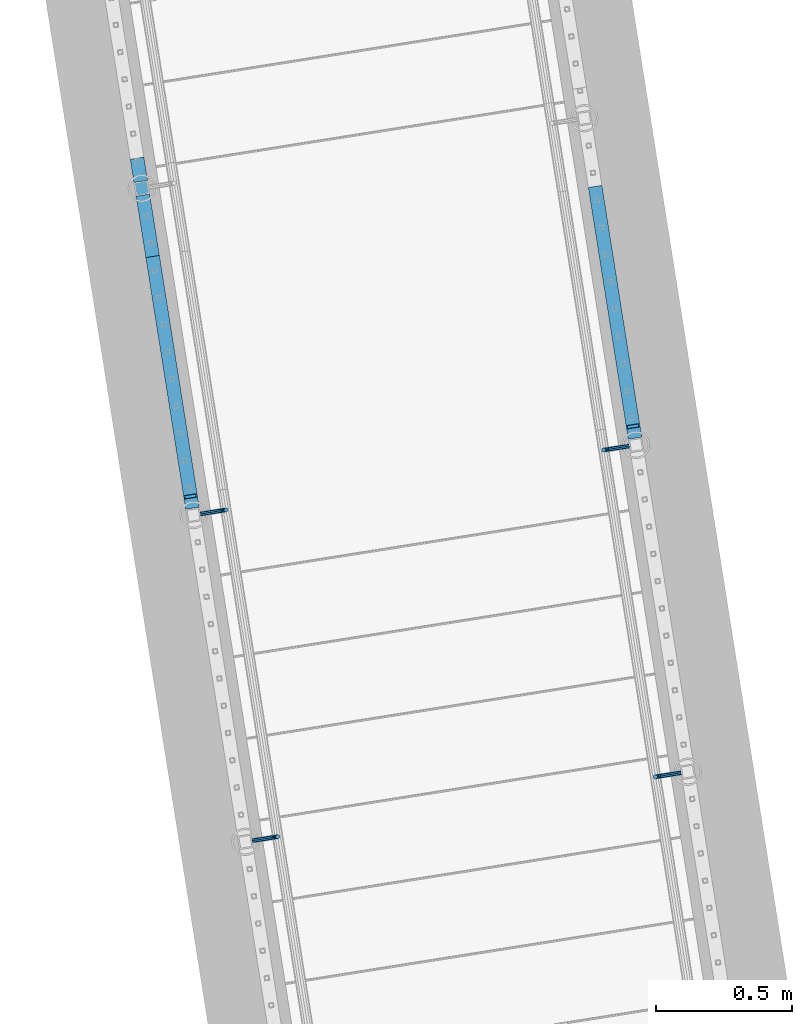
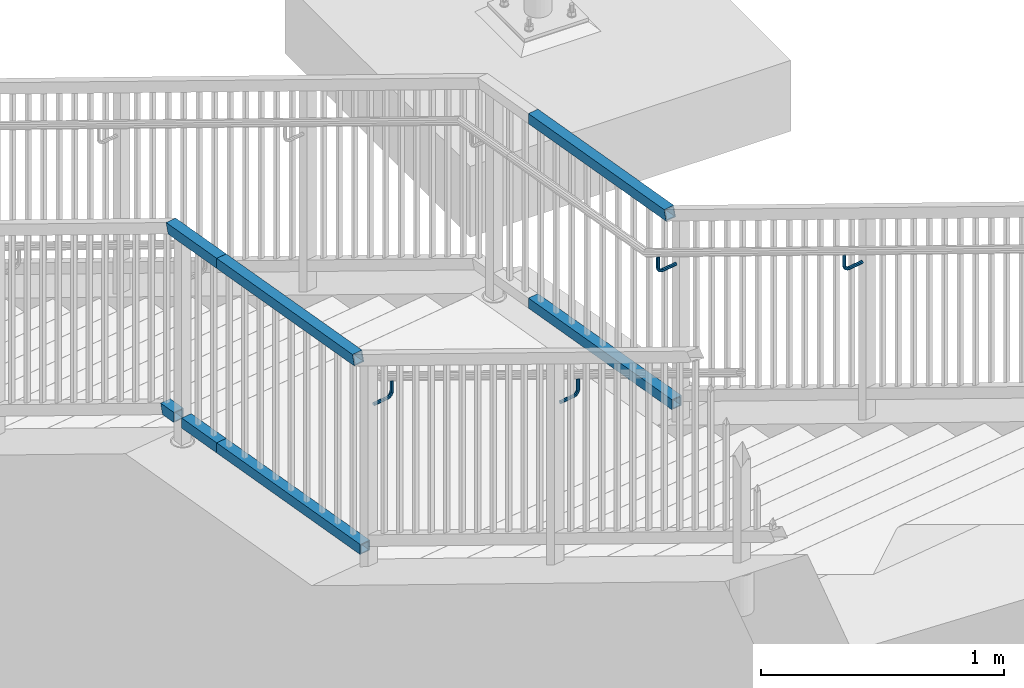
# One storey, part 436 of 975: 11 beams.
"""IFC2X3 building model written with IfcOpenShell, lengths in millimetres."""

import ifcopenshell
import ifcopenshell.guid

model = None  # the IFC model being written
_history = None  # IfcOwnerHistory: only IFC2X3 demands one
_inside = {}  # id of a spatial element -> (the spatial element, [elements in it])
_under = {}  # id of a project, library or spatial element -> (it, [spatial elements below it])
_declared = {}  # id of a project -> (the project, [libraries it declares])
_typed = {}  # id of a type object -> (the type object, [elements of that type])
_made_of = {}  # id of a material, layer set ... -> (it, [elements and type objects made of it])


def new_model(schema):
    """Start an empty IFC model of exactly this schema.

    Asked for "IFC4X3", IfcOpenShell would pick the latest addendum, in which some entities
    have other attributes; the version numbers below select the first issue.
    IFC2X3 requires an IfcOwnerHistory on every rooted entity: one is made here for all.
    """
    global model, _history
    if schema == "IFC4X3":
        model = ifcopenshell.file(schema_version=(4, 3, 0, 0))
    else:
        model = ifcopenshell.file(schema=schema)
    _inside.clear()
    _under.clear()
    _declared.clear()
    _typed.clear()
    _made_of.clear()
    _history = None
    if model.schema == "IFC2X3":
        org = make("IfcOrganization", Name="unknown")
        user = make(
            "IfcPersonAndOrganization",
            ThePerson=make("IfcPerson", FamilyName="unknown"),
            TheOrganization=org,
        )
        app = make(
            "IfcApplication",
            ApplicationDeveloper=org,
            Version="unknown",
            ApplicationFullName="unknown",
            ApplicationIdentifier="unknown",
        )
        _history = make(
            "IfcOwnerHistory",
            OwningUser=user,
            OwningApplication=app,
            ChangeAction="ADDED",
            CreationDate=0,
        )
    return model


def make(cls, **values):
    """One entity of the class cls with the attributes given. An attribute that is None is left unset."""
    return model.create_entity(
        cls, **{name: value for name, value in values.items() if value is not None}
    )


def rooted(cls, **values):
    """An entity with a GlobalId (a new one), such as an element, a storey or a relation."""
    return make(cls, GlobalId=ifcopenshell.guid.new(), OwnerHistory=_history, **values)


def si_unit(unit_type, name, prefix=None):
    """IfcSIUnit, for example si_unit("LENGTHUNIT", "METRE", prefix="MILLI")."""
    return make("IfcSIUnit", UnitType=unit_type, Prefix=prefix, Name=name)


def assignment(units):
    """IfcUnitAssignment: the units of a project."""
    return None if units is None else make("IfcUnitAssignment", Units=units)


def point(xyz):
    """IfcCartesianPoint."""
    return None if xyz is None else make("IfcCartesianPoint", Coordinates=xyz)


def direction(xyz):
    """IfcDirection."""
    return None if xyz is None else make("IfcDirection", DirectionRatios=xyz)


def frame(location, z_axis=None, x_axis=None):
    """IfcAxis2Placement3D, a coordinate frame: its origin and axes. An axis left out is left unset."""
    return make(
        "IfcAxis2Placement3D",
        Location=point(location),
        Axis=direction(z_axis),
        RefDirection=direction(x_axis),
    )


def origin_with_axes():
    """The frame at (0, 0, 0) with the z axis (0, 0, 1) and the x axis (1, 0, 0) written out."""
    return frame((0.0, 0.0, 0.0), z_axis=(0.0, 0.0, 1.0), x_axis=(1.0, 0.0, 0.0))


def place(relative_to, where):
    """IfcLocalPlacement: puts the frame where relative to a parent placement (None: the world)."""
    return make(
        "IfcLocalPlacement", PlacementRelTo=relative_to, RelativePlacement=where
    )


def context(
    kind, dimensions, precision=None, world=None, true_north=None, identifier=None
):
    """IfcGeometricRepresentationContext, for example the 3D "Model" context."""
    return make(
        "IfcGeometricRepresentationContext",
        ContextIdentifier=identifier,
        ContextType=kind,
        CoordinateSpaceDimension=dimensions,
        Precision=precision,
        WorldCoordinateSystem=world,
        TrueNorth=true_north,
    )


def subcontext(parent, identifier, kind, view, scale=None):
    """IfcGeometricRepresentationSubContext, for example "Body" below "Model"."""
    return make(
        "IfcGeometricRepresentationSubContext",
        ContextIdentifier=identifier,
        ContextType=kind,
        ParentContext=parent,
        TargetScale=scale,
        TargetView=view,
    )


def project(units=None, contexts=None):
    """IfcProject with its units and contexts."""
    return rooted(
        "IfcProject",
        Name="project",
        RepresentationContexts=contexts,
        UnitsInContext=assignment(units),
    )


def spatial(cls, under=None, at=None, **own):
    """A site, building, storey or space (cls), placed at a placement, below another one or the project."""
    s = rooted(cls, ObjectPlacement=at, **own)
    if under is not None:
        _under.setdefault(under.id(), (under, []))[1].append(s)
    return s


def faces_of(points, faces, orient=None, outer=None):
    """IfcFace entities. A face is a list of loops; a loop is a list of indices into points, from 0.

    orient and outer hold one flag for each loop. By default every Orientation is true, the
    first loop of a face is its IfcFaceOuterBound and the others are IfcFaceBound.
    """
    made = []
    for i, loops in enumerate(faces):
        bounds = []
        for j, loop in enumerate(loops):
            is_outer = j == 0 if outer is None else outer[i][j]
            bounds.append(
                make(
                    "IfcFaceOuterBound" if is_outer else "IfcFaceBound",
                    Bound=make("IfcPolyLoop", Polygon=[points[k] for k in loop]),
                    Orientation=True if orient is None else orient[i][j],
                )
            )
        made.append(make("IfcFace", Bounds=bounds))
    return made


def faceted_brep(points, faces, orient=None, outer=None, voids=None):
    """IfcFacetedBrep: a solid bounded by flat faces; with voids (closed shells), ...WithVoids."""
    shared = [point(p) for p in points]
    hull = make("IfcClosedShell", CfsFaces=faces_of(shared, faces, orient, outer))
    if voids is None:
        return make("IfcFacetedBrep", Outer=hull)
    return make(
        "IfcFacetedBrepWithVoids",
        Outer=hull,
        Voids=[
            make(cls, CfsFaces=faces_of(shared, fs, o, b)) for cls, fs, o, b in voids
        ],
    )


def shape(context_of_items, identifier, shape_type, items):
    """IfcShapeRepresentation: the items that make up one representation, for example the "Body"."""
    return make(
        "IfcShapeRepresentation",
        ContextOfItems=context_of_items,
        RepresentationIdentifier=identifier,
        RepresentationType=shape_type,
        Items=items,
    )


def material(Name=None, Category=None):
    """IfcMaterial."""
    return make("IfcMaterial", Name=Name, Category=Category)


def made_of(thing, what):
    """Note that an element or type object is made of a material, layer set ...; save() writes the relation."""
    if what is not None:
        _made_of.setdefault(what.id(), (what, []))[1].append(thing)
    return thing


def type_object(cls, material=None, **own):
    """A type object (cls), such as IfcWallType, which elements share."""
    return made_of(rooted(cls, **own), material)


def element(
    cls,
    number,
    at=None,
    inside=None,
    cuts=None,
    type_object=None,
    material=None,
    context=None,
    identifier="Body",
    shape_type=None,
    held_by="IfcProductDefinitionShape",
    body=None,
    shapes=None,
    **own,
):
    """One element of the class cls, such as IfcWall. Its Tag is "e" and its number.

    at: its placement. inside: the storey or other place that contains it. cuts: it is an
    opening in that element (IfcRelVoidsElement). A single representation is given by context,
    identifier, shape_type and body (its items); several are given by shapes. held_by: the class
    of the entity that holds the representations. save() writes the other relations.
    """
    e = rooted(cls, Tag="e%d" % number, ObjectPlacement=at, **own)
    if body is not None:
        shapes = [shape(context, identifier, shape_type, body)]
    if shapes is not None:
        e.Representation = make(held_by, Representations=shapes)
    if inside is not None:
        _inside.setdefault(inside.id(), (inside, []))[1].append(e)
    if cuts is not None:
        rooted(
            "IfcRelVoidsElement", RelatingBuildingElement=cuts, RelatedOpeningElement=e
        )
    if type_object is not None:
        _typed.setdefault(type_object.id(), (type_object, []))[1].append(e)
    return made_of(e, material)


def aggregate(whole, parts):
    """IfcRelAggregates: a whole, such as a stair, and the parts it consists of."""
    return rooted("IfcRelAggregates", RelatingObject=whole, RelatedObjects=parts)


def save(model, path):
    """Write the relations noted so far, then the file.

    IfcRelAggregates (storeys below a building ...), IfcRelContainedInSpatialStructure (elements
    in a storey), IfcRelDefinesByType, IfcRelAssociatesMaterial and IfcRelDeclares: one each for
    every whole, place, type object, material and project.
    """
    for whole, parts in _under.values():
        aggregate(whole, parts)
    for where, things in _inside.values():
        rooted(
            "IfcRelContainedInSpatialStructure",
            RelatedElements=things,
            RelatingStructure=where,
        )
    for kind, things in _typed.values():
        rooted("IfcRelDefinesByType", RelatedObjects=things, RelatingType=kind)
    for what, things in _made_of.values():
        rooted("IfcRelAssociatesMaterial", RelatedObjects=things, RelatingMaterial=what)
    for by, libraries in _declared.values():
        rooted("IfcRelDeclares", RelatingContext=by, RelatedDefinitions=libraries)
    model.write(path)


model = new_model("IFC2X3")

# Units and contexts
model_context = context("Model", 3, precision=1e-05, world=origin_with_axes())
body_context = subcontext(model_context, "Body", "Model", "MODEL_VIEW")
ifc_project = project(units=[si_unit("LENGTHUNIT", "METRE", prefix="MILLI"), si_unit("AREAUNIT", "SQUARE_METRE"), si_unit("VOLUMEUNIT", "CUBIC_METRE"), si_unit("MASSUNIT", "GRAM", prefix="KILO"), si_unit("TIMEUNIT", "SECOND"), si_unit("PLANEANGLEUNIT", "RADIAN"), si_unit("SOLIDANGLEUNIT", "STERADIAN"), si_unit("THERMODYNAMICTEMPERATUREUNIT", "DEGREE_CELSIUS"), si_unit("LUMINOUSINTENSITYUNIT", "LUMEN")], contexts=[model_context])

# Site, building, storey
site_placement = place(None, origin_with_axes())
site = spatial("IfcSite", under=ifc_project, at=site_placement, CompositionType="ELEMENT")
building_placement = place(site_placement, origin_with_axes())
building = spatial("IfcBuilding", under=site, at=building_placement, Name="Undefined", CompositionType="ELEMENT")
storey_placement = place(building_placement, origin_with_axes())
storey = spatial("IfcBuildingStorey", under=building, at=storey_placement, Name="Undefined", CompositionType="ELEMENT", Elevation=0.0)

# Beams
ifc_material_1 = material(Name="STEEL/A36")
beam_type_1 = type_object("IfcBeamType", PredefinedType="NOTDEFINED")
beam_1_placement = place(storey_placement, frame((-326.624516463408, 23059.0157620059, 3529.15078908755), z_axis=(0.0, 0.0, 1.0), x_axis=(-0.987688087180544, -0.156436065028609, -6.10000029016374e-08)))
element("IfcBeam", 1, at=beam_1_placement, inside=storey, type_object=beam_type_1, material=ifc_material_1, Name="BRACKET", context=body_context, shape_type="Brep", body=[
    faceted_brep([(-4.22995071858168e-07, -7.93750000000728, 0.0), (-2.99107341561466e-07, -5.61266007567065, -5.61266007566792), (69.8538229342985, -5.61266007557424, -5.61266006823735), (69.8538229337023, -7.93749999991269, 7.43239070288837e-09), (-1.09139364212751e-11, 1.81898940354586e-12, -7.9375), (69.8538229345472, 1.01863406598568e-10, -7.93749999257216), (2.99089151667431e-07, 5.61266007567428, -5.61266007566792), (69.8538229343008, 5.61266007577433, -5.61266006824189), (4.22980519942939e-07, 7.93750000001091, 0.0), (69.8538229337046, 7.93750000009823, 7.42511474527419e-09), (2.99089151667431e-07, 5.61266007567428, 5.61266007566792), (69.853822933107, 5.61266007575978, 5.61266008309485), (-1.09139364212751e-11, 1.81898940354586e-12, 7.9375), (69.8538229328592, 8.73114913702011e-11, 7.93750000742784), (-2.99107341561466e-07, -5.61266007567065, 5.61266007566792), (69.8538229331057, -5.61266007558515, 5.61266008309849), (82.6115306457523, 1.20053300634027e-10, -5.39983437816591), (81.7218529981346, -5.61266007556333, -3.25196232492181), (79.5739811551193, -7.93749999990177, 1.93345951625906), (77.4261093121045, -5.61266007558152, 7.11888135743811), (76.5364316644896, 9.09494701772928e-11, 9.26675341067767), (77.4261093121072, 5.61266007577069, 7.11888135743357), (79.5739811551225, 7.93750000011642, 1.9334595162527), (81.7218529981369, 5.61266007578888, -3.25196232492635), (91.7830833834992, 5.61266007579252, 3.47073613356315), (93.4269933452169, 1.2732925824821e-10, 1.82682594394737), (87.8143336585977, 7.93750000012005, 7.43948640866074), (83.8455839336962, 5.6126600757816, 11.408236683762), (82.2016739719761, 9.82254277914762e-11, 13.0521468733814), (83.8455839336939, -5.61266007557424, 11.4082366837665), (87.8143336585954, -7.93749999989814, 7.43948640866802), (91.7830833834973, -5.61266007555241, 3.4707361335677), (98.5057832368084, 5.61266007579252, 13.5319655869434), (100.653655166712, 1.23691279441118e-10, 12.6422876415645), (93.3203616933934, 7.93750000011642, 15.6798381488252), (88.1349401499765, 5.61266007577797, 17.8277107107078), (85.9870682200708, 9.82254277914762e-11, 18.7173886560922), (88.1349401499742, -5.61266007557424, 17.8277107107133), (93.3203616933897, -7.93749999990177, 15.6798381488315), (98.5057832368066, -5.61266007555605, 13.5319655869471), (100.86648262542, 5.61266007578524, 25.3999953235088), (103.191322549751, 1.12777343019843e-10, 25.3999950009666), (95.2538225497506, 7.93750000010914, 25.3999961022027), (89.6411624740808, 5.61266007576705, 25.3999968808967), (87.3163225497478, 9.09494701772928e-11, 25.3999972034444), (89.641162474079, -5.61266007557788, 25.3999968809012), (95.2538225497483, -7.93749999990905, 25.3999961022082), (100.866482625418, -5.61266007556333, 25.3999953235143), (103.191329597684, 6.54836185276508e-11, 76.2000105823545), (100.866489243451, -5.61266007561062, 73.1013772833176), (95.2538289897093, -7.93749999994907, 71.8178769012538), (89.6411690921104, -5.61266007562517, 73.1013665526652), (87.3163295976792, 4.36557456851006e-11, 76.1999954069215), (89.6411699519131, 5.61266007571612, 79.2986287059584), (95.2538302056541, 7.93750000005821, 80.5821290880222), (100.866490103253, 5.61266007573067, 79.2986394366098)], [[[0, 1, 2, 3]], [[1, 4, 5, 2]], [[4, 6, 7, 5]], [[6, 8, 9, 7]], [[8, 10, 11, 9]], [[10, 12, 13, 11]], [[12, 14, 15, 13]], [[14, 0, 3, 15]], [[14, 12, 10, 8, 6, 4, 1, 0]], [[2, 5, 16, 17]], [[3, 2, 17, 18]], [[15, 3, 18, 19]], [[13, 15, 19, 20]], [[11, 13, 20, 21]], [[9, 11, 21, 22]], [[7, 9, 22, 23]], [[5, 7, 23, 16]], [[23, 24, 25, 16]], [[22, 26, 24, 23]], [[21, 27, 26, 22]], [[20, 28, 27, 21]], [[19, 29, 28, 20]], [[18, 30, 29, 19]], [[17, 31, 30, 18]], [[16, 25, 31, 17]], [[24, 32, 33, 25]], [[26, 34, 32, 24]], [[27, 35, 34, 26]], [[28, 36, 35, 27]], [[29, 37, 36, 28]], [[30, 38, 37, 29]], [[31, 39, 38, 30]], [[25, 33, 39, 31]], [[32, 40, 41, 33]], [[34, 42, 40, 32]], [[35, 43, 42, 34]], [[36, 44, 43, 35]], [[37, 45, 44, 36]], [[38, 46, 45, 37]], [[39, 47, 46, 38]], [[33, 41, 47, 39]], [[47, 41, 48, 49]], [[46, 47, 49, 50]], [[45, 46, 50, 51]], [[44, 45, 51, 52]], [[43, 44, 52, 53]], [[42, 43, 53, 54]], [[40, 42, 54, 55]], [[41, 40, 55, 48]], [[54, 53, 52, 51, 50, 49, 48, 55]]]),
])
beam_2_placement = place(storey_placement, frame((-1907.32451436722, 22808.6574775025, 3529.15078908755), z_axis=(0.0, 0.0, 1.0), x_axis=(0.987688352468583, 0.156434390074216, -6.09999983468464e-08)))
element("IfcBeam", 2, at=beam_2_placement, inside=storey, type_object=beam_type_1, material=ifc_material_1, Name="BRACKET", context=body_context, shape_type="Brep", body=[
    faceted_brep([(-4.22995071858168e-07, -7.93750000000728, 0.0), (-2.99107341561466e-07, -5.61266007567065, -5.61266007566792), (69.8503542524265, -5.61266011719636, -5.61266006824098), (69.8503542509172, -7.93750004153844, 7.13935150997713e-08), (-1.09139364212751e-11, 1.81898940354586e-12, -7.9375), (69.8503542548774, -4.15166141465306e-08, -7.93749999257489), (2.99089151667431e-07, 5.61266007567428, -5.61266007566792), (69.850354256834, 5.61266003415949, -5.61266006824462), (4.22980519942939e-07, 7.93750000001091, 0.0), (69.8503542571498, 7.93749995848702, 7.42329575587064e-09), (2.99089151667431e-07, 5.61266007567428, 5.61266007566792), (69.8503542556402, 5.61266003414494, 5.61266008309212), (-1.09139364212751e-11, 1.81898940354586e-12, 7.9375), (69.8503542531901, -4.1531166061759e-08, 7.93750000742511), (-2.99107341561466e-07, -5.61266007567065, 5.61266007566792), (69.8503542512333, -5.61266011720727, 5.61266008309485), (82.6080619660092, -1.59849150804803e-07, -5.39983437818319), (81.7183842570932, -5.61266021300253, -3.25196229146422), (79.5705123886862, -7.93750008296047, 1.9334595635828), (77.422640571061, -5.61266010424515, 7.11888139089478), (76.5329629847436, -6.04632077738643e-09, 9.26675341066039), (77.42264069366, 5.61266004711069, 7.11888132394142), (79.5705125620677, 7.93749991707227, 1.93345946889531), (81.7183843796927, 5.61265993835332, -3.2519623584185), (91.7796148150826, 5.61265980362077, 3.4707361335004), (93.4235246654027, -3.04684363072738e-07, 1.82682594388461), (87.8108651363229, 7.93749980671782, 7.4394864085989), (83.842115365278, 5.61265996114525, 11.4082366836983), (82.1982052921601, -8.1912730820477e-08, 13.0521468733186), (83.8421151424809, -5.61266019021059, 11.4082366837029), (87.8108648212394, -7.93750019330764, 7.43948640860435), (91.7796145922794, -5.61266034773871, 3.47073613349858), (98.5023147018187, 5.61265960524179, 13.5319656369056), (100.650186486849, -5.1793540478684e-07, 12.6422876414272), (93.316893218411, 7.93749964423841, 15.6798382195402), (88.1314716149859, 5.61265983456542, 17.8277107606718), (85.9835995402068, -1.93616870092228e-07, 18.7173886559558), (88.1314713252375, -5.61266031678679, 17.8277106604774), (93.3168928086452, -7.93750035579069, 15.6798380778428), (98.5023144120698, -5.6126605461177, 13.5319655367102), (100.86301410217, 5.61265937340795, 25.399995432489), (103.187853869874, -7.6714059105143e-07, 25.3999950007492), (95.2503540913781, 7.93749945436502, 25.3999962564121), (89.6376939508302, 5.61265968664884, 25.3999969898769), (87.3128538698681, -3.24151187669486e-07, 25.3999972032288), (89.6376936375721, -5.61266046470701, 25.399996771489), (95.2503537123291, -7.93750054566044, 25.3999959475659), (100.863013788912, -5.61266077794789, 25.3999952141021), (103.187860917806, -1.69155464391224e-06, 76.2000016572638), (100.863019348813, -5.61265993605048, 79.2986355177381), (95.2503593334475, -7.93749986544572, 80.5821299535055), (89.6376991974728, -5.61265996815928, 79.2986343738849), (87.3128609178009, -1.37649476528168e-06, 76.2000038597416), (89.6376989062965, 5.61266013009663, 73.101372264261), (95.2503589216619, 7.93750005948823, 71.8178778284946), (100.863019057636, 5.61266016220543, 73.1013734081143)], [[[0, 1, 2, 3]], [[1, 4, 5, 2]], [[4, 6, 7, 5]], [[6, 8, 9, 7]], [[8, 10, 11, 9]], [[10, 12, 13, 11]], [[12, 14, 15, 13]], [[14, 0, 3, 15]], [[14, 12, 10, 8, 6, 4, 1, 0]], [[2, 5, 16, 17]], [[3, 2, 17, 18]], [[15, 3, 18, 19]], [[13, 15, 19, 20]], [[11, 13, 20, 21]], [[9, 11, 21, 22]], [[7, 9, 22, 23]], [[5, 7, 23, 16]], [[23, 24, 25, 16]], [[22, 26, 24, 23]], [[21, 27, 26, 22]], [[20, 28, 27, 21]], [[19, 29, 28, 20]], [[18, 30, 29, 19]], [[17, 31, 30, 18]], [[16, 25, 31, 17]], [[24, 32, 33, 25]], [[26, 34, 32, 24]], [[27, 35, 34, 26]], [[28, 36, 35, 27]], [[29, 37, 36, 28]], [[30, 38, 37, 29]], [[31, 39, 38, 30]], [[25, 33, 39, 31]], [[32, 40, 41, 33]], [[34, 42, 40, 32]], [[35, 43, 42, 34]], [[36, 44, 43, 35]], [[37, 45, 44, 36]], [[38, 46, 45, 37]], [[39, 47, 46, 38]], [[33, 41, 47, 39]], [[47, 41, 48, 49]], [[46, 47, 49, 50]], [[45, 46, 50, 51]], [[44, 45, 51, 52]], [[43, 44, 52, 53]], [[42, 43, 53, 54]], [[40, 42, 54, 55]], [[41, 40, 55, 48]], [[54, 53, 52, 51, 50, 49, 48, 55]]]),
])
beam_3_placement = place(storey_placement, frame((-517.34941673155, 24263.2053867639, 2856.05209496575), z_axis=(0.0, 0.0, 1.0), x_axis=(-0.987688087180544, -0.156436065028609, -6.10000029016374e-08)))
element("IfcBeam", 3, at=beam_3_placement, inside=storey, type_object=beam_type_1, material=ifc_material_1, Name="BRACKET", context=body_context, shape_type="Brep", body=[
    faceted_brep([(-4.22995071858168e-07, -7.93750000000728, 0.0), (-2.99107341561466e-07, -5.61266007567065, -5.61266007566792), (69.8538229342985, -5.61266007557424, -5.61266006823735), (69.8538229337023, -7.93749999991269, 7.43239070288837e-09), (-1.09139364212751e-11, 1.81898940354586e-12, -7.9375), (69.8538229345472, 1.01863406598568e-10, -7.93749999257216), (2.99089151667431e-07, 5.61266007567428, -5.61266007566792), (69.8538229343008, 5.61266007577433, -5.61266006824189), (4.22980519942939e-07, 7.93750000001091, 0.0), (69.8538229337046, 7.93750000009823, 7.42511474527419e-09), (2.99089151667431e-07, 5.61266007567428, 5.61266007566792), (69.853822933107, 5.61266007575978, 5.61266008309485), (-1.09139364212751e-11, 1.81898940354586e-12, 7.9375), (69.8538229328592, 8.73114913702011e-11, 7.93750000742784), (-2.99107341561466e-07, -5.61266007567065, 5.61266007566792), (69.8538229331057, -5.61266007558515, 5.61266008309849), (82.6115306457523, 1.20053300634027e-10, -5.39983437816591), (81.7218529981346, -5.61266007556333, -3.25196232492181), (79.5739811551193, -7.93749999990177, 1.93345951625906), (77.4261093121045, -5.61266007558152, 7.11888135743811), (76.5364316644896, 9.09494701772928e-11, 9.26675341067767), (77.4261093121072, 5.61266007577069, 7.11888135743357), (79.5739811551225, 7.93750000011642, 1.9334595162527), (81.7218529981369, 5.61266007578888, -3.25196232492635), (91.7830833834992, 5.61266007579252, 3.47073613356315), (93.4269933452169, 1.2732925824821e-10, 1.82682594394737), (87.8143336585977, 7.93750000012005, 7.43948640866074), (83.8455839336962, 5.6126600757816, 11.408236683762), (82.2016739719761, 9.82254277914762e-11, 13.0521468733814), (83.8455839336939, -5.61266007557424, 11.4082366837665), (87.8143336585954, -7.93749999989814, 7.43948640866802), (91.7830833834973, -5.61266007555241, 3.4707361335677), (98.5057832368084, 5.61266007579252, 13.5319655869434), (100.653655166712, 1.23691279441118e-10, 12.6422876415645), (93.3203616933934, 7.93750000011642, 15.6798381488252), (88.1349401499765, 5.61266007577797, 17.8277107107078), (85.9870682200708, 9.82254277914762e-11, 18.7173886560922), (88.1349401499742, -5.61266007557424, 17.8277107107133), (93.3203616933897, -7.93749999990177, 15.6798381488315), (98.5057832368066, -5.61266007555605, 13.5319655869471), (100.86648262542, 5.61266007578524, 25.3999953235088), (103.191322549751, 1.12777343019843e-10, 25.3999950009666), (95.2538225497506, 7.93750000010914, 25.3999961022027), (89.6411624740808, 5.61266007576705, 25.3999968808967), (87.3163225497478, 9.09494701772928e-11, 25.3999972034444), (89.641162474079, -5.61266007557788, 25.3999968809012), (95.2538225497483, -7.93749999990905, 25.3999961022082), (100.866482625418, -5.61266007556333, 25.3999953235143), (103.191329597684, 6.54836185276508e-11, 76.2000105823545), (100.866489243451, -5.61266007561062, 73.1013772833176), (95.2538289897093, -7.93749999994907, 71.8178769012538), (89.6411690921104, -5.61266007562517, 73.1013665526652), (87.3163295976792, 4.36557456851006e-11, 76.1999954069215), (89.6411699519131, 5.61266007571612, 79.2986287059584), (95.2538302056541, 7.93750000005821, 80.5821290880222), (100.866490103253, 5.61266007573067, 79.2986394366098)], [[[0, 1, 2, 3]], [[1, 4, 5, 2]], [[4, 6, 7, 5]], [[6, 8, 9, 7]], [[8, 10, 11, 9]], [[10, 12, 13, 11]], [[12, 14, 15, 13]], [[14, 0, 3, 15]], [[14, 12, 10, 8, 6, 4, 1, 0]], [[2, 5, 16, 17]], [[3, 2, 17, 18]], [[15, 3, 18, 19]], [[13, 15, 19, 20]], [[11, 13, 20, 21]], [[9, 11, 21, 22]], [[7, 9, 22, 23]], [[5, 7, 23, 16]], [[23, 24, 25, 16]], [[22, 26, 24, 23]], [[21, 27, 26, 22]], [[20, 28, 27, 21]], [[19, 29, 28, 20]], [[18, 30, 29, 19]], [[17, 31, 30, 18]], [[16, 25, 31, 17]], [[24, 32, 33, 25]], [[26, 34, 32, 24]], [[27, 35, 34, 26]], [[28, 36, 35, 27]], [[29, 37, 36, 28]], [[30, 38, 37, 29]], [[31, 39, 38, 30]], [[25, 33, 39, 31]], [[32, 40, 41, 33]], [[34, 42, 40, 32]], [[35, 43, 42, 34]], [[36, 44, 43, 35]], [[37, 45, 44, 36]], [[38, 46, 45, 37]], [[39, 47, 46, 38]], [[33, 41, 47, 39]], [[47, 41, 48, 49]], [[46, 47, 49, 50]], [[45, 46, 50, 51]], [[44, 45, 51, 52]], [[43, 44, 52, 53]], [[42, 43, 53, 54]], [[40, 42, 54, 55]], [[41, 40, 55, 48]], [[54, 53, 52, 51, 50, 49, 48, 55]]]),
])
beam_4_placement = place(storey_placement, frame((-2098.04941463316, 24012.8471022576, 2856.05209496575), z_axis=(0.0, 0.0, 1.0), x_axis=(0.987688352468583, 0.156434390074216, -6.09999983468464e-08)))
element("IfcBeam", 4, at=beam_4_placement, inside=storey, type_object=beam_type_1, material=ifc_material_1, Name="BRACKET", context=body_context, shape_type="Brep", body=[
    faceted_brep([(-4.22995071858168e-07, -7.93750000000728, 0.0), (-2.99107341561466e-07, -5.61266007567065, -5.61266007566792), (69.8503542524265, -5.61266011719636, -5.61266006824098), (69.8503542509172, -7.93750004153844, 7.13935150997713e-08), (-1.09139364212751e-11, 1.81898940354586e-12, -7.9375), (69.8503542548774, -4.15166141465306e-08, -7.93749999257489), (2.99089151667431e-07, 5.61266007567428, -5.61266007566792), (69.850354256834, 5.61266003415949, -5.61266006824462), (4.22980519942939e-07, 7.93750000001091, 0.0), (69.8503542571498, 7.93749995848702, 7.42329575587064e-09), (2.99089151667431e-07, 5.61266007567428, 5.61266007566792), (69.8503542556402, 5.61266003414494, 5.61266008309212), (-1.09139364212751e-11, 1.81898940354586e-12, 7.9375), (69.8503542531901, -4.1531166061759e-08, 7.93750000742511), (-2.99107341561466e-07, -5.61266007567065, 5.61266007566792), (69.8503542512333, -5.61266011720727, 5.61266008309485), (82.6080619660092, -1.59849150804803e-07, -5.39983437818319), (81.7183842570932, -5.61266021300253, -3.25196229146422), (79.5705123886862, -7.93750008296047, 1.9334595635828), (77.422640571061, -5.61266010424515, 7.11888139089478), (76.5329629847436, -6.04632077738643e-09, 9.26675341066039), (77.42264069366, 5.61266004711069, 7.11888132394142), (79.5705125620677, 7.93749991707227, 1.93345946889531), (81.7183843796927, 5.61265993835332, -3.2519623584185), (91.7796148150826, 5.61265980362077, 3.4707361335004), (93.4235246654027, -3.04684363072738e-07, 1.82682594388461), (87.8108651363229, 7.93749980671782, 7.4394864085989), (83.842115365278, 5.61265996114525, 11.4082366836983), (82.1982052921601, -8.1912730820477e-08, 13.0521468733186), (83.8421151424809, -5.61266019021059, 11.4082366837029), (87.8108648212394, -7.93750019330764, 7.43948640860435), (91.7796145922794, -5.61266034773871, 3.47073613349858), (98.5023147018187, 5.61265960524179, 13.5319656369056), (100.650186486849, -5.1793540478684e-07, 12.6422876414272), (93.316893218411, 7.93749964423841, 15.6798382195402), (88.1314716149859, 5.61265983456542, 17.8277107606718), (85.9835995402068, -1.93616870092228e-07, 18.7173886559558), (88.1314713252375, -5.61266031678679, 17.8277106604774), (93.3168928086452, -7.93750035579069, 15.6798380778428), (98.5023144120698, -5.6126605461177, 13.5319655367102), (100.86301410217, 5.61265937340795, 25.399995432489), (103.187853869874, -7.6714059105143e-07, 25.3999950007492), (95.2503540913781, 7.93749945436502, 25.3999962564121), (89.6376939508302, 5.61265968664884, 25.3999969898769), (87.3128538698681, -3.24151187669486e-07, 25.3999972032288), (89.6376936375721, -5.61266046470701, 25.399996771489), (95.2503537123291, -7.93750054566044, 25.3999959475659), (100.863013788912, -5.61266077794789, 25.3999952141021), (103.187860917806, -1.69155464391224e-06, 76.2000016572638), (100.863019348813, -5.61265993605048, 79.2986355177381), (95.2503593334475, -7.93749986544572, 80.5821299535055), (89.6376991974728, -5.61265996815928, 79.2986343738849), (87.3128609178009, -1.37649476528168e-06, 76.2000038597416), (89.6376989062965, 5.61266013009663, 73.101372264261), (95.2503589216619, 7.93750005948823, 71.8178778284946), (100.863019057636, 5.61266016220543, 73.1013734081143)], [[[0, 1, 2, 3]], [[1, 4, 5, 2]], [[4, 6, 7, 5]], [[6, 8, 9, 7]], [[8, 10, 11, 9]], [[10, 12, 13, 11]], [[12, 14, 15, 13]], [[14, 0, 3, 15]], [[14, 12, 10, 8, 6, 4, 1, 0]], [[2, 5, 16, 17]], [[3, 2, 17, 18]], [[15, 3, 18, 19]], [[13, 15, 19, 20]], [[11, 13, 20, 21]], [[9, 11, 21, 22]], [[7, 9, 22, 23]], [[5, 7, 23, 16]], [[23, 24, 25, 16]], [[22, 26, 24, 23]], [[21, 27, 26, 22]], [[20, 28, 27, 21]], [[19, 29, 28, 20]], [[18, 30, 29, 19]], [[17, 31, 30, 18]], [[16, 25, 31, 17]], [[24, 32, 33, 25]], [[26, 34, 32, 24]], [[27, 35, 34, 26]], [[28, 36, 35, 27]], [[29, 37, 36, 28]], [[30, 38, 37, 29]], [[31, 39, 38, 30]], [[25, 33, 39, 31]], [[32, 40, 41, 33]], [[34, 42, 40, 32]], [[35, 43, 42, 34]], [[36, 44, 43, 35]], [[37, 45, 44, 36]], [[38, 46, 45, 37]], [[39, 47, 46, 38]], [[33, 41, 47, 39]], [[47, 41, 48, 49]], [[46, 47, 49, 50]], [[45, 46, 50, 51]], [[44, 45, 51, 52]], [[43, 44, 52, 53]], [[42, 43, 53, 54]], [[40, 42, 54, 55]], [[41, 40, 55, 48]], [[54, 53, 52, 51, 50, 49, 48, 55]]]),
])
ifc_material_2 = material()
beam_type_2 = type_object("IfcBeamType", Name="HSS2X2X.188_TUBES", PredefinedType="NOTDEFINED")
beam_5_placement = place(storey_placement, frame((-2274.04073666458, 24961.6666920638, 2133.59469360166), z_axis=(-0.987688340611262, -0.156434464938429, 0.0), x_axis=(-0.156434465059671, 0.987688340376754, 2.06230000081987e-05)))
element("IfcBeam", 5, at=beam_5_placement, inside=storey, type_object=beam_type_2, material=ifc_material_2, Name="HANDRAIL", ObjectType="HSS2X2X.188_TUBES", context=body_context, shape_type="Brep", body=[
    faceted_brep([(0.0, 20.6374999999753, -20.6375000000298), (0.0, -20.6375000000153, -20.6375000000153), (229.130921046417, -20.6375000000367, -20.6375000000335), (229.130069832139, 20.6374999999562, -20.6375000000498), (0.0, -20.6374999999825, 20.6375000000335), (229.13092105282, -20.6375000000371, 20.6374999999766), (0.0, 20.6375000000116, 20.6375000000189), (229.130069838538, 20.6374999999557, 20.6374999999603), (0.0, 25.3999999999724, -25.4000000000342), (0.0, 25.400000000016, 25.4000000000196), (229.129971622242, 25.3999999999551, 25.3999999999592), (229.129971614369, 25.3999999999555, -25.4000000000528), (0.0, -25.399999999976, 25.4000000000378), (229.13101927059, -25.400000000036, 25.3999999999801), (0.0, -25.400000000016, -25.4000000000196), (229.131019262713, -25.400000000036, -25.4000000000328)], [[[0, 1, 2, 3]], [[1, 4, 5, 2]], [[4, 6, 7, 5]], [[6, 0, 3, 7]], [[8, 9, 10, 11]], [[9, 12, 13, 10]], [[12, 14, 15, 13]], [[14, 8, 11, 15]], [[13, 15, 11, 10], [5, 7, 3, 2]], [[14, 12, 9, 8], [6, 4, 1, 0]]]),
])
beam_6_placement = place(storey_placement, frame((-2274.0398942961, 24961.6613693907, 3060.69469322725), z_axis=(-0.987688340611262, -0.156434464938429, 0.0), x_axis=(-0.156434462967251, 0.987688340793221, 1.60399999960537e-05)))
element("IfcBeam", 6, at=beam_6_placement, inside=storey, type_object=beam_type_2, material=ifc_material_2, Name="HANDRAIL", ObjectType="HSS2X2X.188_TUBES", context=body_context, shape_type="Brep", body=[
    faceted_brep([(0.0, 20.6374999999753, -20.6375000000298), (0.0, -20.6375000000153, -20.6375000000153), (329.50910839827, -20.6374999999975, -20.6374999999166), (318.87182856576, 20.6374999999998, -20.637499999928), (0.0, -20.6374999999825, 20.6375000000335), (329.509108355713, -20.6374999999975, 20.6375000000812), (0.0, 20.6375000000116, 20.6375000000189), (318.871828523203, 20.6375000000003, 20.6375000000698), (0.0, 25.3999999999724, -25.4000000000342), (0.0, 25.400000000016, 25.4000000000196), (317.644450076081, 25.4000000000001, 25.4000000000683), (317.64445012846, 25.4000000000001, -25.3999999999287), (0.0, -25.399999999976, 25.4000000000378), (330.736486793016, -25.3999999999974, 25.4000000000824), (0.0, -25.400000000016, -25.4000000000196), (330.736486845395, -25.3999999999974, -25.3999999999155)], [[[0, 1, 2, 3]], [[1, 4, 5, 2]], [[4, 6, 7, 5]], [[6, 0, 3, 7]], [[8, 9, 10, 11]], [[9, 12, 13, 10]], [[12, 14, 15, 13]], [[14, 8, 11, 15]], [[13, 15, 11, 10], [5, 7, 3, 2]], [[14, 12, 9, 8], [6, 4, 1, 0]]]),
])
beam_7_placement = place(storey_placement, frame((-2123.13318770216, 24008.8739270724, 2133.59994282072), z_axis=(-0.987688340611262, -0.156434464938429, 0.0), x_axis=(-0.156434464936115, 0.987688340596641, -5.4409999976752e-06)))
element("IfcBeam", 7, at=beam_7_placement, inside=storey, type_object=beam_type_2, material=ifc_material_2, Name="HANDRAIL", ObjectType="HSS2X2X.188_TUBES", context=body_context, shape_type="Brep", body=[
    faceted_brep([(25.3940604148047, 20.6375000000012, -20.6374999999994), (25.3940948917116, -20.6374999999907, -20.6375000000021), (964.668784640398, -20.6374999997888, -20.6375000000435), (964.668784640435, 20.6375000002022, -20.6375000000407), (25.394094891737, -20.6374999999907, 20.6374999999985), (964.668784640427, -20.6374999997888, 20.6374999999562), (25.3940604148302, 20.6375000000012, 20.6375000000012), (964.668784640464, 20.6375000002022, 20.6374999999593), (25.3940564366967, 25.4000000000001, -25.3999999999992), (25.3940564367294, 25.4000000000001, 25.4000000000019), (964.668784640471, 25.4000000002015, 25.3999999999605), (964.668784640438, 25.4000000002015, -25.400000000041), (25.3940988698414, -25.3999999999896, 25.3999999999987), (964.668784640427, -25.3999999997882, 25.3999999999569), (25.3940988698123, -25.3999999999896, -25.4000000000028), (964.668784640395, -25.3999999997882, -25.4000000000447)], [[[0, 1, 2, 3]], [[1, 4, 5, 2]], [[4, 6, 7, 5]], [[6, 0, 3, 7]], [[8, 9, 10, 11]], [[9, 12, 13, 10]], [[12, 14, 15, 13]], [[14, 8, 11, 15]], [[13, 15, 11, 10], [5, 7, 3, 2]], [[14, 12, 9, 8], [6, 4, 1, 0]]]),
])
beam_8_placement = place(storey_placement, frame((-2135.05349285258, 24084.1357510372, 3060.70000358198), z_axis=(-0.987688340611262, -0.156434464938429, 0.0), x_axis=(-0.156434464936115, 0.987688340596641, -5.4409999976752e-06)))
element("IfcBeam", 8, at=beam_8_placement, inside=storey, type_object=beam_type_2, material=ifc_material_2, Name="HANDRAIL", ObjectType="HSS2X2X.188_TUBES", context=body_context, shape_type="Brep", body=[
    faceted_brep([(-11.8641257585441, 20.6375000000025, -20.6375000000023), (-1.22733041973697, -20.637500000003, -20.6375000000055), (888.45822242412, -20.6375000000025, -20.637499999985), (888.458222424102, 20.637500000003, -20.6374999999809), (-1.22733050487295, -20.637500000003, 20.6375000000005), (888.458222424077, -20.6375000000025, 20.637500000021), (-11.8641258436764, 20.6375000000025, 20.6375000000041), (888.458222424062, 20.637500000003, 20.6375000000246), (-13.091448287807, 25.4000000000033, -25.4000000000026), (-13.0914483925881, 25.4000000000033, 25.4000000000044), (888.458222424055, 25.4000000000037, 25.4000000000258), (888.458222424106, 25.4000000000037, -25.3999999999817), (0.0, -25.399999999976, 25.4000000000378), (888.458222424077, -25.4000000000028, 25.4000000000212), (0.0, -25.400000000016, -25.4000000000196), (888.458222424128, -25.4000000000028, -25.3999999999867)], [[[0, 1, 2, 3]], [[1, 4, 5, 2]], [[4, 6, 7, 5]], [[6, 0, 3, 7]], [[8, 9, 10, 11]], [[9, 12, 13, 10]], [[12, 14, 15, 13]], [[14, 8, 11, 15]], [[13, 15, 11, 10], [5, 7, 3, 2]], [[14, 12, 9, 8], [6, 4, 1, 0]]]),
])
beam_9_placement = place(storey_placement, frame((-2313.85807854837, 25213.0634948951, 2133.59994282035), z_axis=(-0.987688340611262, -0.156434464938429, 0.0), x_axis=(-0.156434502935552, 0.987688334593108, 0.0)))
element("IfcBeam", 9, at=beam_9_placement, inside=storey, type_object=beam_type_2, material=ifc_material_2, Name="HANDRAIL", ObjectType="HSS2X2X.188_TUBES", context=body_context, shape_type="Brep", body=[
    faceted_brep([(25.3999997357314, 20.6374999999898, -20.6374999999998), (25.4000002641624, -20.6375000000153, -20.6374999999998), (111.013059006644, -20.637499999993, -20.637500000036), (100.376130028711, 20.6375000000066, -20.6375000000337), (25.4000002641624, -20.6375000000153, 20.6374999999998), (111.013059315101, -20.637499999993, 20.6374999999641), (25.3999997357314, 20.6374999999898, 20.6374999999998), (100.376130337165, 20.6375000000066, 20.6374999999664), (25.4000003077635, 25.3999999999942, -25.3999999999996), (25.3999996747552, 25.3999999999905, 25.3999999999996), (99.1487924137691, 25.4000000000065, 25.3999999999662), (99.1487920341242, 25.4000000000065, -25.4000000000331), (25.4000003251349, -25.4000000000124, 25.3999999999996), (112.240397309681, -25.3999999999933, 25.3999999999635), (25.4000003077854, -25.4000000000087, -25.3999999999996), (112.240396930043, -25.3999999999933, -25.4000000000362)], [[[0, 1, 2, 3]], [[1, 4, 5, 2]], [[4, 6, 7, 5]], [[6, 0, 3, 7]], [[8, 9, 10, 11]], [[9, 12, 13, 10]], [[12, 14, 15, 13]], [[14, 8, 11, 15]], [[13, 15, 11, 10], [5, 7, 3, 2]], [[14, 12, 9, 8], [6, 4, 1, 0]]]),
])
beam_10_placement = place(storey_placement, frame((-492.265555980203, 24267.1779841905, 2133.59994282072), z_axis=(0.987688352468583, 0.156434390074216, -6.09999983468464e-08), x_axis=(-0.156434464936115, 0.987688340596641, -5.4409999976752e-06)))
element("IfcBeam", 10, at=beam_10_placement, inside=storey, type_object=beam_type_2, material=ifc_material_2, Name="HANDRAIL", ObjectType="HSS2X2X.188_TUBES", context=body_context, shape_type="Brep", body=[
    faceted_brep([(25.3999997357314, 20.6374999999898, -20.6374999999998), (25.4002529136851, -20.6375000000012, -20.637499999998), (964.668784640398, -20.6374999997888, -20.6375000000435), (964.668784640435, 20.6375000002022, -20.6375000000407), (25.4002529136524, -20.6375000000012, 20.637499999998), (964.668784640427, -20.6374999997888, 20.6374999999562), (25.3999997357314, 20.6374999999898, 20.6374999999998), (964.668784640464, 20.6375000002022, 20.6374999999593), (25.4000003077635, 25.3999999999942, -25.3999999999996), (25.3999996747552, 25.3999999999905, 25.3999999999996), (964.668784640471, 25.4000000002015, 25.3999999999605), (964.668784640438, 25.4000000002015, -25.400000000041), (25.4002788405305, -25.4000000000001, 25.3999999999983), (964.668784640427, -25.3999999997882, 25.3999999999569), (25.4002788405669, -25.4000000000001, -25.3999999999969), (964.668784640395, -25.3999999997882, -25.4000000000447)], [[[0, 1, 2, 3]], [[1, 4, 5, 2]], [[4, 6, 7, 5]], [[6, 0, 3, 7]], [[8, 9, 10, 11]], [[9, 12, 13, 10]], [[12, 14, 15, 13]], [[14, 8, 11, 15]], [[13, 15, 11, 10], [5, 7, 3, 2]], [[14, 12, 9, 8], [6, 4, 1, 0]]]),
])
beam_11_placement = place(storey_placement, frame((-504.18585468197, 24342.4398091712, 3060.70000358198), z_axis=(0.987688352468583, 0.156434390074216, -6.09999983468464e-08), x_axis=(-0.156434464936115, 0.987688340596641, -5.4409999976752e-06)))
element("IfcBeam", 11, at=beam_11_placement, inside=storey, type_object=beam_type_2, material=ifc_material_2, Name="HANDRAIL", ObjectType="HSS2X2X.188_TUBES", context=body_context, shape_type="Brep", body=[
    faceted_brep([(-1.22733174164023, 20.6375000000021, -20.6374999999962), (-11.8641270607986, -20.6375000000025, -20.637499999998), (888.463525788975, -20.6375000000025, -20.6375000001372), (888.463525788993, 20.637500000003, -20.6375000001344), (-11.864127135279, -20.6375000000025, 20.6374999999998), (888.463525788957, -20.6375000000025, 20.6374999998598), (-1.22733181612421, 20.6375000000021, 20.6375000000012), (888.463525788979, 20.637500000003, 20.6374999998638), (0.0, 25.3999999999724, -25.4000000000342), (0.0, 25.400000000016, 25.4000000000196), (888.463525788982, 25.4000000000033, 25.3999999998637), (888.463525788997, 25.4000000000033, -25.4000000001338), (-13.0914496807018, -25.4000000000033, 25.3999999999996), (888.463525788953, -25.4000000000033, 25.3999999998591), (-13.091449589032, -25.4000000000033, -25.3999999999978), (888.463525788975, -25.4000000000033, -25.4000000001374)], [[[0, 1, 2, 3]], [[1, 4, 5, 2]], [[4, 6, 7, 5]], [[6, 0, 3, 7]], [[8, 9, 10, 11]], [[9, 12, 13, 10]], [[12, 14, 15, 13]], [[14, 8, 11, 15]], [[13, 15, 11, 10], [5, 7, 3, 2]], [[14, 12, 9, 8], [6, 4, 1, 0]]]),
])

save(model, "model.ifc")
